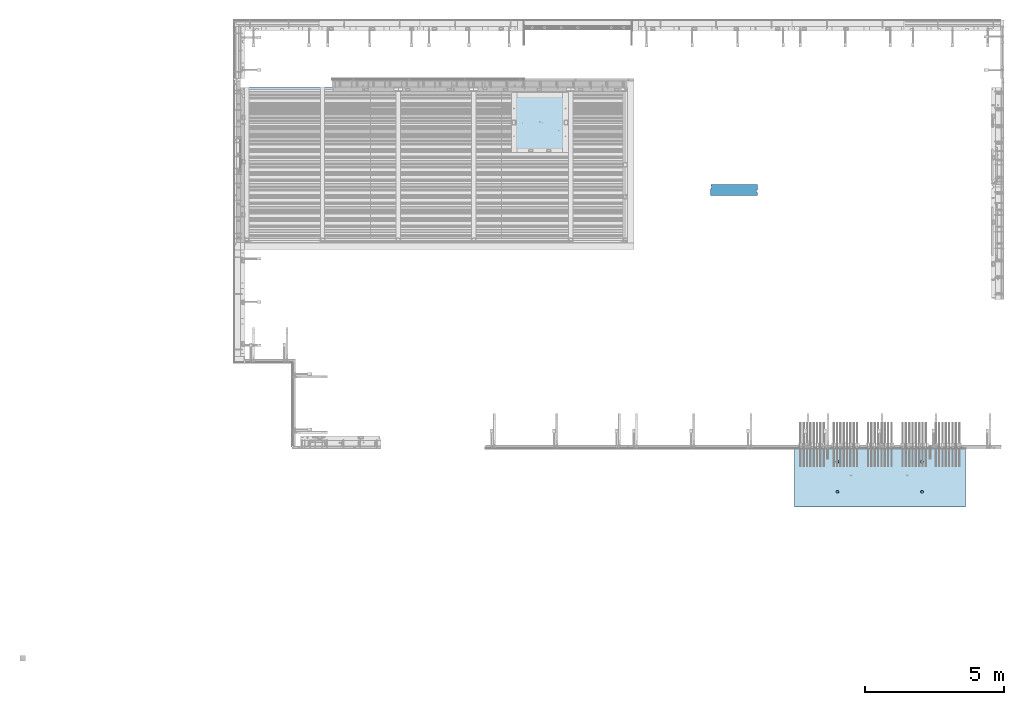
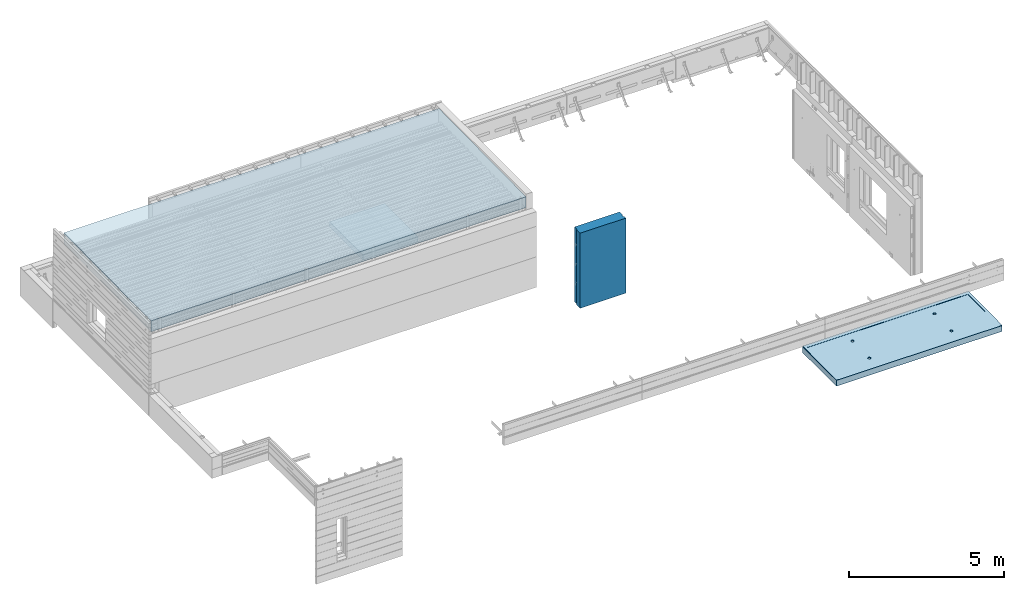
# One storey, part 69 of 153: 3 slabs, 2 plates, 4 elements without a shape of their own.
"""IFC2X3 building model written with IfcOpenShell, lengths in millimetres."""

from ifc_helpers import new_model, si_unit, frame, origin_with_axes, place, context, subcontext, project, spatial, faceted_brep, material, type_object, element, aggregate, save


model = new_model("IFC2X3")

# Units and contexts
model_context = context("Model", 3, precision=1e-05, world=origin_with_axes())
body_context = subcontext(model_context, "Body", "Model", "MODEL_VIEW")
ifc_project = project(units=[si_unit("LENGTHUNIT", "METRE", prefix="MILLI"), si_unit("AREAUNIT", "SQUARE_METRE"), si_unit("VOLUMEUNIT", "CUBIC_METRE"), si_unit("MASSUNIT", "GRAM", prefix="KILO"), si_unit("TIMEUNIT", "SECOND"), si_unit("PLANEANGLEUNIT", "RADIAN"), si_unit("SOLIDANGLEUNIT", "STERADIAN"), si_unit("THERMODYNAMICTEMPERATUREUNIT", "DEGREE_CELSIUS"), si_unit("LUMINOUSINTENSITYUNIT", "LUMEN")], contexts=[model_context])

# Site, building, storey
site_placement = place(None, origin_with_axes())
site = spatial("IfcSite", under=ifc_project, at=site_placement, CompositionType="ELEMENT")
building_placement = place(site_placement, origin_with_axes())
building = spatial("IfcBuilding", under=site, at=building_placement, CompositionType="ELEMENT")
storey_placement = place(building_placement, origin_with_axes())
storey = spatial("IfcBuildingStorey", under=building, at=storey_placement, Name="8", CompositionType="ELEMENT", Elevation=0.0)

# Assembly, slab
assembly_1_placement = place(storey_placement, origin_with_axes())
assembly_1 = element("IfcElementAssembly", 1, at=assembly_1_placement, inside=storey, AssemblyPlace="NOTDEFINED", PredefinedType="REINFORCEMENT_UNIT")
ifc_material_1 = material(Name="CONCRETE/C35/45")
slab_type_1 = type_object("IfcSlabType", PredefinedType="NOTDEFINED")
slab_1_placement = place(assembly_1_placement, frame((27819.9998568017, 7630.00344419876, 102715.0), z_axis=(-1.11800000013248e-06, -0.999999999999375, 0.0), x_axis=(0.999999999999375, -1.11799999997436e-06, 0.0)))
slab_1 = element("IfcSlab", 2, at=slab_1_placement, type_object=slab_type_1, material=ifc_material_1, PredefinedType="FLOOR", context=body_context, shape_type="Brep", body=[
    faceted_brep([(1589.81325592552, 0.909604111424414, 566.199296128498), (1588.0938311348, -15.0000000000146, 565.640623273063), (1580.9111665252, -15.0000000000146, 579.737435254802), (1582.36061370195, 0.766201307793381, 580.790517794936), (1569.72389207501, -15.0000000000146, 590.924734719762), (1570.76938061005, 0.652459661185276, 592.363722854278), (1555.62709615375, -15.0000000000146, 598.107430849813), (1556.17417970693, 0.579462587236776, 599.791174489762), (1540.00067136433, -15.0000000000146, 600.582431302958), (1540.00067334043, 0.554314810113283, 602.349967076835), (1524.37424104085, -15.0000000000146, 598.107465790505), (1523.82716125849, 0.579462416979368, 599.791210635328), (1510.27742905911, -15.0000000000146, 590.924801180907), (1509.2319437633, 0.652459337215987, 592.363791623349), (1499.09012959415, -15.0000000000146, 579.737526730721), (1497.64068481311, 0.766200861689867, 580.790612482018), (1491.9074334641, -15.0000000000146, 565.640730809456), (1490.18800997929, 0.909603586653247, 566.199407491095), (1489.43243301096, -15.0000000000146, 550.014306020037), (1487.60644765718, 1.06867111324391, 550.014308061489), (1491.90739852341, -15.0000000000146, 534.387875696556), (1490.15357958405, 1.22784849844174, 533.818027547306), (1499.090063133, -15.0000000000146, 520.291063714818), (1497.58496496165, 1.37153884480358, 519.197548455435), (1510.27733758319, -15.0000000000146, 509.103764249858), (1509.17619797228, 1.48563591431594, 507.58817916073), (1524.37413350445, -15.0000000000146, 501.921068119807), (1523.79265561132, 1.5589205318538, 500.131469988689), (1540.00055829388, -15.0000000000146, 499.446067666661), (1540.00055618693, 1.58417814118729, 497.561501968798), (1555.62698861736, -15.0000000000146, 501.921033179116), (1556.20846251496, 1.55892070285336, 500.131433729337), (1569.72380059909, -15.0000000000146, 509.103697788713), (1570.82493684288, 1.48563623946393, 507.588110207549), (1580.91110006406, -15.0000000000146, 520.290972238898), (1582.41619583143, 1.3715392920858, 519.197453584243), (1588.09379619411, -15.0000000000146, 534.387768160163), (1589.84761391607, 1.22784902394051, 533.817916070923), (1590.56879664725, -15.0000000000146, 550.014192949582), (1592.39478206378, 1.06867166540178, 550.014190908131), (100.000169136605, 4.99999899105751, 149.999887195343), (6060.00016913566, 4.99999303130608, 150.003242675352), (6060.00016914429, 13.626982540809, 150.003242675352), (100.000169145234, 13.6270007889543, 149.999887195343), (6059.99902340923, -15.0, 2184.99381483995), (6059.99902341922, -5.00001173831697, 2184.99381483995), (-0.000976555282250047, -15.0, 2185.00366210937), (99.9990234313627, -15.0, 2185.00349961318), (99.9990234413635, -4.99999981843575, 2185.00349961318), (-0.000976555282250047, -4.99999961843423, 2185.00366210937), (0.0, -15.0, 0.0), (0.0, 15.0, 0.0), (6159.99999999999, -15.0, 1.20053300634027e-10), (6159.99999999877, 14.9999889917381, 0.00275350808988151), (6159.9990234375, -15.0, 2184.99365234375), (6159.9990234375, -5.00001193831849, 2184.99365234375), (1589.77710511953, -9.43578378019447, 1618.84121999299), (1589.17575487276, -15.0000000000146, 1619.03661127579), (1591.70637331362, -15.0000000000146, 1635.01419167845), (1592.32060830134, -9.59473210806027, 1635.01419099173), (1582.35637965208, -9.29230025924335, 1604.24179400386), (1581.83164984091, -15.0000000000146, 1604.62303342371), (1570.78179862371, -9.17836747907859, 1592.64915460789), (1570.39295038797, -15.0000000000146, 1593.18435954767), (1556.18635505503, -9.10518846024934, 1585.20320708963), (1555.97935611451, -15.0000000000146, 1585.8402867446), (1540.00176930131, -9.07996736333007, 1582.63697304818), (1540.00177005342, -15.0000000000146, 1583.30970402962), (1523.81718929172, -9.10518863100151, 1585.20324329681), (1524.02418965076, -15.0000000000146, 1585.84032247048), (1509.22176238791, -9.17836780374637, 1592.64922346186), (1509.61061179868, -15.0000000000146, 1593.18442750233), (1497.64720730009, -9.29230070589983, 1604.24188873855), (1498.17193792265, -15.0000000000146, 1604.62312695526), (1490.22651449262, -9.43578430493653, 1618.84133130897), (1490.82786511957, -15.0000000000146, 1619.03672122873), (1487.68304747952, -9.59473265943234, 1635.01430797653), (1488.29728240459, -15.0000000000146, 1635.01430728981), (1490.26089534804, -9.75357131339842, 1651.17611964729), (1490.82790084545, -15.0000000000146, 1650.99188769248), (1497.70284697964, -9.89676770487858, 1665.7463302375), (1498.1720058773, -15.0000000000146, 1665.40546554456), (1509.27742796969, -10.0103455735516, 1677.30285743263), (1509.61070533024, -15.0000000000146, 1676.84413942059), (1523.85164529082, -10.0832374629535, 1684.71958958146), (1524.0242996037, -15.0000000000146, 1684.18821222366), (1540.00188628625, -10.1083488864388, 1687.27466438337), (1540.00188566478, -15.0000000000146, 1686.71879493864), (1556.15212157446, -10.083237292929, 1684.7195534879), (1555.97946606745, -15.0000000000146, 1684.18817649779), (1570.72632232738, -10.010345250048, 1677.30278876251), (1570.39304391953, -15.0000000000146, 1676.84407146594), (1582.30087749635, -9.8967672594008, 1665.74623568666), (1581.83171779556, -15.0000000000146, 1665.405372013), (1589.74279656461, -9.75357078936941, 1651.17600844493), (1589.17579059863, -15.0000000000146, 1650.99177773954), (4639.77710685512, -9.4357677033986, 1618.83780952844), (4639.17575487085, -15.0000000000146, 1619.03320137579), (4641.70637331171, -15.0000000000146, 1635.01078177845), (4642.32061012571, -9.59471603682323, 1635.01078109173), (4632.35638112863, -9.29228417745617, 1604.23838302969), (4631.831649839, -15.0000000000146, 1604.6196235237), (4620.78179969623, -9.17835139330418, 1592.64574322906), (4620.39295038606, -15.0000000000146, 1593.18094964767), (4606.18635561807, -9.10517237192835, 1585.19979545089), (4605.97935611261, -15.0000000000146, 1585.8368768446), (4590.0017692994, -9.07995127410686, 1582.63356131986), (4590.00177005151, -15.0000000000146, 1583.30629412962), (4573.81718872486, -9.10517254266597, 1585.19983165807), (4574.02418964885, -15.0000000000146, 1585.83691257048), (4559.22176131157, -9.17835171795741, 1592.64581208303), (4559.61061179677, -15.0000000000146, 1593.18101760233), (4547.64720581972, -9.2922846240981, 1604.23847776439), (4548.17193792074, -15.0000000000146, 1604.61971705526), (4540.22651275322, -9.43576822814066, 1618.83792084443), (4540.82786511767, -15.0000000000146, 1619.03331132873), (4537.68304565134, -9.5947165881953, 1635.01089807653), (4538.29728240268, -15.0000000000146, 1635.01089738981), (4540.26089360985, -9.75355524769111, 1651.17271031145), (4540.82790084355, -15.0000000000146, 1650.98847779248), (4547.70284550121, -9.89675164416258, 1665.74292141026), (4548.1720058754, -15.0000000000146, 1665.40205564456), (4559.27742689529, -10.0103295168083, 1677.29944900879), (4559.61070532833, -15.0000000000146, 1676.84072952059), (4573.85164472516, -10.0832214087568, 1684.71618141651), (4574.02429960179, -15.0000000000146, 1684.18480232366), (4590.00188628434, -10.1083328331297, 1687.27125630761), (4590.00188566288, -15.0000000000146, 1686.71538503864), (4606.15212213631, -10.0832212387468, 1684.71614532295), (4605.97946606554, -15.0000000000146, 1684.18476659779), (4620.72632339797, -10.0103291933046, 1677.29938033867), (4620.39304391763, -15.0000000000146, 1676.84066156594), (4632.30087897097, -9.89675119869935, 1665.74282685941), (4631.83171779366, -15.0000000000146, 1665.401962113), (4639.742798299, -9.75355472367664, 1651.17259910908), (4639.17579059672, -15.0000000000146, 1650.98836783954), (4560.27742905721, -15.0000000000146, 590.921391280907), (4559.2319426889, 0.652475393959321, 592.360383199507), (4573.82716069284, 0.579478471161565, 599.787802470379), (4574.37424103894, -15.0000000000146, 598.104055890504), (4549.09012959224, -15.0000000000146, 579.734116830721), (4547.64068333468, 0.766216922391322, 580.787203654775), (4541.9074334622, -15.0000000000146, 565.637320909456), (4540.18800824109, 0.909619652346009, 566.195998155254), (4539.43243300905, -15.0000000000146, 550.010896120038), (4537.60644582899, 1.06868718448095, 550.010898161491), (4541.90739852151, -15.0000000000146, 534.384465796556), (4540.15357784466, 1.22786457523762, 533.814617082763), (4549.0900631311, -15.0000000000146, 520.287653814817), (4547.58496348128, 1.37155492659076, 519.194137481273), (4560.27733758129, -15.0000000000146, 509.100354349858), (4559.17619689594, 1.48565200009034, 507.584767781906), (4574.37413350255, -15.0000000000146, 501.917658219807), (4573.79265504446, 1.55893662018934, 500.128058349949), (4590.00055829197, -15.0000000000146, 499.442657766662), (4590.00055618502, 1.58419423039595, 497.558090240479), (4605.62698861545, -15.0000000000146, 501.917623279115), (4606.208463078, 1.55893679117435, 500.128022090596), (4619.72380059719, -15.0000000000146, 509.100287888714), (4620.8249379154, 1.48565232523833, 507.584698828722), (4630.91110006215, -15.0000000000146, 520.287562338897), (4632.41619730799, 1.37155537388753, 519.194042610077), (4638.0937961922, -15.0000000000146, 534.384358260164), (4639.84761565166, 1.22786510073638, 533.814505606375), (4632.36061517657, 0.766217368509388, 580.787108967689), (4620.76938168064, 0.65247571792861, 592.360314430433), (4606.17418026878, 0.579478641418973, 599.787766324812), (4590.00067333853, 0.554330863422365, 602.346559001076), (4642.39478388815, 1.06868773663882, 550.010781008129), (4639.81325765991, 0.909620177117176, 566.195886792653), (4590.00067136242, -15.0000000000146, 600.579021402958), (4605.62709615185, -15.0000000000146, 598.104020949812), (4619.72389207311, -15.0000000000146, 590.921324819762), (4630.9111665233, -15.0000000000146, 579.734025354802), (4638.09383113289, -15.0000000000146, 565.637213373064), (4640.56879664535, -15.0000000000146, 550.010783049583)], [[[0, 1, 2, 3]], [[3, 2, 4, 5]], [[5, 4, 6, 7]], [[7, 6, 8, 9]], [[10, 11, 9, 8]], [[12, 13, 11, 10]], [[14, 15, 13, 12]], [[16, 17, 15, 14]], [[18, 19, 17, 16]], [[20, 21, 19, 18]], [[22, 23, 21, 20]], [[24, 25, 23, 22]], [[26, 27, 25, 24]], [[27, 26, 28, 29]], [[29, 28, 30, 31]], [[31, 30, 32, 33]], [[33, 32, 34, 35]], [[35, 34, 36, 37]], [[37, 36, 38, 39]], [[39, 38, 1, 0]], [[40, 41, 42, 43]], [[41, 44, 45, 42]], [[46, 47, 48, 49]], [[50, 46, 49, 51]], [[52, 50, 51, 53]], [[54, 52, 53, 55]], [[44, 54, 55, 45]], [[53, 51, 49, 48, 43, 42, 45, 55]], [[47, 40, 43, 48]], [[56, 57, 58, 59]], [[60, 61, 57, 56]], [[62, 63, 61, 60]], [[64, 65, 63, 62]], [[66, 67, 65, 64]], [[68, 69, 67, 66]], [[70, 71, 69, 68]], [[71, 70, 72, 73]], [[73, 72, 74, 75]], [[75, 74, 76, 77]], [[77, 76, 78, 79]], [[79, 78, 80, 81]], [[81, 80, 82, 83]], [[83, 82, 84, 85]], [[85, 84, 86, 87]], [[87, 86, 88, 89]], [[90, 91, 89, 88]], [[92, 93, 91, 90]], [[94, 95, 93, 92]], [[59, 58, 95, 94]], [[96, 97, 98, 99]], [[100, 101, 97, 96]], [[102, 103, 101, 100]], [[104, 105, 103, 102]], [[106, 107, 105, 104]], [[108, 109, 107, 106]], [[110, 111, 109, 108]], [[111, 110, 112, 113]], [[113, 112, 114, 115]], [[115, 114, 116, 117]], [[117, 116, 118, 119]], [[119, 118, 120, 121]], [[121, 120, 122, 123]], [[123, 122, 124, 125]], [[125, 124, 126, 127]], [[127, 126, 128, 129]], [[130, 131, 129, 128]], [[132, 133, 131, 130]], [[134, 135, 133, 132]], [[99, 98, 135, 134]], [[136, 137, 138, 139]], [[140, 141, 137, 136]], [[142, 143, 141, 140]], [[144, 145, 143, 142]], [[146, 147, 145, 144]], [[148, 149, 147, 146]], [[150, 151, 149, 148]], [[152, 153, 151, 150]], [[153, 152, 154, 155]], [[155, 154, 156, 157]], [[157, 156, 158, 159]], [[159, 158, 160, 161]], [[161, 160, 162, 163]], [[44, 41, 40, 47], [3, 5, 7, 9, 11, 13, 15, 17, 19, 21, 23, 25, 27, 29, 31, 33, 35, 37, 39, 0], [164, 165, 166, 167, 138, 137, 141, 143, 145, 147, 149, 151, 153, 155, 157, 159, 161, 163, 168, 169], [132, 130, 128, 126, 124, 122, 120, 118, 116, 114, 112, 110, 108, 106, 104, 102, 100, 96, 99, 134], [92, 90, 88, 86, 84, 82, 80, 78, 76, 74, 72, 70, 68, 66, 64, 62, 60, 56, 59, 94]], [[139, 138, 167, 170]], [[166, 171, 170, 167]], [[165, 172, 171, 166]], [[164, 173, 172, 165]], [[169, 174, 173, 164]], [[168, 175, 174, 169]], [[163, 162, 175, 168]], [[46, 50, 52, 54, 44, 47], [34, 32, 30, 28, 26, 24, 22, 20, 18, 16, 14, 12, 10, 8, 6, 4, 2, 1, 38, 36], [160, 158, 156, 154, 152, 150, 148, 146, 144, 142, 140, 136, 139, 170, 171, 172, 173, 174, 175, 162], [101, 103, 105, 107, 109, 111, 113, 115, 117, 119, 121, 123, 125, 127, 129, 131, 133, 135, 98, 97], [61, 63, 65, 67, 69, 71, 73, 75, 77, 79, 81, 83, 85, 87, 89, 91, 93, 95, 58, 57]]]),
])

# Assembly, plate
assembly_2_placement = place(storey_placement, origin_with_axes())
assembly_2 = element("IfcElementAssembly", 3, at=assembly_2_placement, inside=storey, Name="Steel Assembly", AssemblyPlace="NOTDEFINED", PredefinedType="NOTDEFINED")
ifc_material_2 = material()
plate_type_1 = type_object("IfcPlateType", PredefinedType="NOTDEFINED")
plate_1_placement = place(assembly_2_placement, frame((21787.0, 20572.0405139231, 106106.758710679), z_axis=(0.0, -0.999921884110963, -0.0124990270013851), x_axis=(-1.0, 3.00000001838171e-08, 0.0)))
plate_1 = element("IfcPlate", 4, at=plate_1_placement, type_object=plate_type_1, material=ifc_material_2, context=body_context, shape_type="Brep", body=[
    faceted_brep([(0.0, -215.000000000015, 0.0), (-0.0013580322265625, -215.000000000015, 5600.0), (-0.0013580322265625, 215.0, 5600.0), (0.0, 215.0, 0.0), (13937.0, -215.000000000015, 5600.0), (13937.0, 215.0, 5600.0), (13937.0, -215.000000000015, -1.38243194669485e-10), (13937.0, 215.0, -1.38243194669485e-10)], [[[0, 1, 2, 3]], [[1, 4, 5, 2]], [[4, 6, 7, 5]], [[6, 0, 3, 7]], [[5, 7, 3, 2]], [[6, 4, 1, 0]]]),
])
aggregate(assembly_2, [plate_1])

# Assembly, slab
assembly_3_placement = place(storey_placement, origin_with_axes())
assembly_3 = element("IfcElementAssembly", 5, at=assembly_3_placement, inside=storey, AssemblyPlace="NOTDEFINED", PredefinedType="REINFORCEMENT_UNIT")
ifc_material_3 = material(Name="CONCRETE/Concrete_Undefined")
slab_type_2 = type_object("IfcSlabType", PredefinedType="NOTDEFINED")
slab_2_placement = place(assembly_3_placement, frame((19659.999681647, 20380.0, 103350.0), z_axis=(0.0, -1.0, 0.0), x_axis=(-1.0, 3.00000001838171e-08, 0.0)))
slab_2 = element("IfcSlab", 6, at=slab_2_placement, type_object=slab_type_2, material=ifc_material_3, PredefinedType="FLOOR", context=body_context, shape_type="Brep", body=[
    faceted_brep([(0.0, -100.0, 0.0), (0.0, -100.0, 2150.00073242188), (0.0, 100.0, 2150.00073242188), (0.0, 100.0, 0.0), (2049.99975585938, -100.0, 2150.00073242188), (2049.99975585938, 100.0, 2150.00073242188), (2049.99975585938, -100.0, 0.0), (2049.99975585938, 100.0, 0.0)], [[[0, 1, 2, 3]], [[1, 4, 5, 2]], [[4, 6, 7, 5]], [[6, 0, 3, 7]], [[5, 7, 3, 2]], [[6, 4, 1, 0]]]),
])
aggregate(assembly_3, [slab_2])

# Assembly, plate
assembly_4_placement = place(storey_placement, origin_with_axes())
assembly_4 = element("IfcElementAssembly", 7, at=assembly_4_placement, inside=storey, Name="Steel Assembly", AssemblyPlace="NOTDEFINED", PredefinedType="NOTDEFINED")
ifc_material_4 = material()
plate_type_2 = type_object("IfcPlateType", PredefinedType="NOTDEFINED")
plate_2_placement = place(assembly_4_placement, frame((24780.0, 16680.0, 101255.600000381), z_axis=(0.0, 1.0, 0.0), x_axis=(1.0, 0.0, 0.0)))
plate_2 = element("IfcPlate", 8, at=plate_2_placement, type_object=plate_type_2, material=ifc_material_4, context=body_context, shape_type="Brep", body=[
    faceted_brep([(1699.99914550781, -1475.0, 110.0), (1699.99914550781, 1475.0, 110.0), (1669.99914550781, 1475.0, 110.0), (1669.99914550781, -1475.00000000001, 110.0), (1669.99914550781, 1475.0, 200.0), (1669.99914550781, -1475.00000000001, 200.0), (1699.99914550781, -1475.0, 200.0), (1699.99914550781, 1475.0, 200.0), (1699.99914550781, -1475.0, 3.63797880709171e-12), (0.0, -1475.0, 0.0), (0.0, 1475.0, 0.0), (1699.99914550781, 1475.0, 3.63797880709171e-12), (0.0, -1475.0, 230.0), (0.0, 1475.0, 230.0), (30.0, -1475.0, 243.0), (30.0, 1475.0, 243.0), (30.0, -1475.0, 400.0), (30.0, 1475.0, 400.0), (1699.99914550781, -1475.0, 400.0), (1699.99914550781, 1475.0, 400.0)], [[[0, 1, 2, 3]], [[3, 2, 4, 5]], [[6, 5, 4, 7]], [[8, 9, 10, 11]], [[10, 9, 12, 13]], [[14, 15, 13, 12]], [[16, 17, 15, 14]], [[18, 19, 17, 16]], [[19, 18, 6, 7]], [[2, 1, 11, 10, 13, 15, 17, 19, 7, 4]], [[8, 11, 1, 0]], [[18, 16, 14, 12, 9, 8, 0, 3, 5, 6]]]),
])
aggregate(assembly_4, [plate_2])

# Slab
slab_type_3 = type_object("IfcSlabType", PredefinedType="NOTDEFINED")
slab_3_placement = place(assembly_1_placement, frame((33979.9998568133, 7629.99655735226, 102585.0), z_axis=(-1.11800000013248e-06, -0.999999999999375, 0.0), x_axis=(-0.999999999999093, 1.34699999998405e-06, 0.0)))
slab_3 = element("IfcSlab", 9, at=slab_3_placement, type_object=slab_type_3, material=ifc_material_1, PredefinedType="FLOOR", context=body_context, shape_type="Brep", body=[
    faceted_brep([(64.9583792620033, 114.980015566543, 2119.00354297346), (59.9583792907433, 104.980015635199, 2119.00353623188), (54.958376556533, 114.980014717788, 2119.00362372717), (64.9417520754141, 114.989717250108, 60.0035430634471), (59.9417521041541, 104.989717318778, 60.0035363218722), (54.9417493699439, 114.989716401367, 60.0036238171633), (1585.449075041, -100.0, 1587.45803107696), (1599.38747999686, -100.0, 1594.56002275611), (1610.44905473413, -100.0, 1605.62162222708), (1617.55101524698, -100.0, 1619.56004306296), (1619.99817215818, -100.0, 1635.01089551764), (1617.55098069888, -100.0, 1650.46174250043), (1610.44898901974, -100.0, 1664.40014745629), (1599.38738954876, -100.0, 1675.46172219355), (1585.44896871288, -100.0, 1682.56368270641), (1569.99811625821, -100.0, 1685.01083961761), (1554.5472692754, -100.0, 1682.56364815832), (1540.60886431955, -100.0, 1675.46165647916), (1529.54728958229, -100.0, 1664.40005700819), (1522.44532906943, -100.0, 1650.46163617231), (1519.99817215824, -100.0, 1635.01078371764), (1522.44536361753, -100.0, 1619.55993673484), (1529.54735529668, -100.0, 1605.62153177898), (1540.60895476765, -100.0, 1594.55995704172), (1554.54737560352, -100.0, 1587.45799652886), (1569.99822805821, -100.0, 1585.01083961767), (1520.82424514455, -115.0, 1619.03320140929), (1518.29362670369, -115.0, 1635.01078181195), (1528.1683501764, -115.0, 1604.61962355721), (1539.60704962934, -115.0, 1593.18094968118), (1554.0206439028, -115.0, 1585.8368768781), (1569.99822996389, -115.0, 1583.30629416312), (1585.97581036655, -115.0, 1585.83691260398), (1600.38938821863, -115.0, 1593.18101763583), (1611.82806209466, -115.0, 1604.61971708877), (1619.17213489774, -115.0, 1619.03331136223), (1621.70271761272, -115.0, 1635.01089742332), (1619.17209917186, -115.0, 1650.98847782598), (1611.82799414001, -115.0, 1665.40205567806), (1600.38929468707, -115.0, 1676.8407295541), (1585.97570041361, -115.0, 1684.18480235717), (1569.99811435253, -115.0, 1686.71538507215), (1554.02053394986, -115.0, 1684.18476663129), (1539.60695609778, -115.0, 1676.84066159944), (1528.16828222174, -115.0, 1665.40196214651), (1520.82420941868, -115.0, 1650.98836787304), (1585.45028807101, -110.0, 502.458031077636), (1599.38869302686, -110.0, 509.560022756788), (1610.45026776412, -110.0, 520.621622227759), (1617.55222827698, -110.0, 534.560043063637), (1619.99938518817, -110.0, 550.010895518315), (1617.55219372888, -110.0, 565.461742501111), (1610.45020204973, -110.0, 579.40014745697), (1599.38860257876, -110.0, 590.461722194232), (1585.45018174289, -110.0, 597.563682707092), (1569.99932928821, -110.0, 600.010839618284), (1554.54848230541, -110.0, 597.563648158993), (1540.61007734955, -110.0, 590.461656479841), (1529.54850261228, -110.0, 579.40005700887), (1522.44654209943, -110.0, 565.461636172992), (1519.99938518824, -110.0, 550.010783718315), (1522.44657664753, -110.0, 534.559936735518), (1529.54856832667, -110.0, 520.62153177966), (1540.61016779765, -110.0, 509.559957042397), (1554.54858863353, -110.0, 502.457996529537), (1569.99944108821, -110.0, 500.010839618346), (1521.9062038232, -115.0, 534.384358293668), (1519.43120337006, -115.0, 550.010783083088), (1529.08889995325, -115.0, 520.287562372401), (1540.27619941821, -115.0, 509.100287922216), (1554.37301139995, -115.0, 501.917623312619), (1569.99944172343, -115.0, 499.442657800165), (1585.62586651286, -115.0, 501.917658253311), (1599.72266243412, -115.0, 509.100354383362), (1610.90993688431, -115.0, 520.287653848321), (1618.0926014939, -115.0, 534.384465830061), (1620.56756700635, -115.0, 550.010896153542), (1618.09256655321, -115.0, 565.637320942961), (1610.90987042316, -115.0, 579.734116864227), (1599.7225709582, -115.0, 590.921391314413), (1585.62575897646, -115.0, 598.10405592401), (1569.99932865298, -115.0, 600.579021436465), (1554.37290386356, -115.0, 598.104020983318), (1540.2761079423, -115.0, 590.921324853267), (1529.08883349211, -115.0, 579.734025388308), (1521.90616888251, -115.0, 565.637213406568), (4635.4490750391, -100.0, 1587.46144097696), (4649.38747999496, -100.0, 1594.56343265611), (4660.44905473222, -100.0, 1605.62503212708), (4667.55101524507, -100.0, 1619.56345296296), (4669.99817215627, -100.0, 1635.01430541764), (4667.55098069697, -100.0, 1650.46515240043), (4660.44898901783, -100.0, 1664.40355735629), (4649.38738954686, -100.0, 1675.46513209355), (4635.44896871098, -100.0, 1682.56709260641), (4619.9981162563, -100.0, 1685.01424951761), (4604.5472692735, -100.0, 1682.56705805831), (4590.60886431765, -100.0, 1675.46506637916), (4579.54728958038, -100.0, 1664.40346690819), (4572.44532906752, -100.0, 1650.46504607232), (4569.99817215633, -100.0, 1635.01419361764), (4572.44536361562, -100.0, 1619.56334663484), (4579.54735529477, -100.0, 1605.62494167898), (4590.60895476575, -100.0, 1594.56336694172), (4604.54737560162, -100.0, 1587.46140642886), (4619.9982280563, -100.0, 1585.01424951767), (4570.82424514264, -115.0, 1619.03661130929), (4568.29362670179, -115.0, 1635.01419171195), (4578.16835017449, -115.0, 1604.62303345721), (4589.60704962743, -115.0, 1593.18435958118), (4604.02064390089, -115.0, 1585.84028677811), (4619.99822996198, -115.0, 1583.30970406312), (4635.97581036465, -115.0, 1585.84032250398), (4650.38938821672, -115.0, 1593.18442753583), (4661.82806209276, -115.0, 1604.62312698877), (4669.17213489583, -115.0, 1619.03672126223), (4671.70271761081, -115.0, 1635.01430732332), (4669.17209916995, -115.0, 1650.99188772598), (4661.8279941381, -115.0, 1665.40546557806), (4650.38929468517, -115.0, 1676.8441394541), (4635.97570041171, -115.0, 1684.18821225717), (4619.99811435062, -115.0, 1686.71879497215), (4604.02053394795, -115.0, 1684.18817653129), (4589.60695609587, -115.0, 1676.84407149944), (4578.16828221984, -115.0, 1665.40537204651), (4570.82420941677, -115.0, 1650.99177777304), (4635.4502880691, -110.0, 502.461440977637), (4649.38869302495, -110.0, 509.563432656789), (4660.45026776222, -110.0, 520.625032127759), (4667.55222827508, -110.0, 534.563452963636), (4669.99938518627, -110.0, 550.014305418315), (4667.55219372698, -110.0, 565.465152401111), (4660.45020204783, -110.0, 579.40355735697), (4649.38860257686, -110.0, 590.465132094232), (4635.45018174098, -110.0, 597.567092607092), (4619.9993292863, -110.0, 600.014249518284), (4604.5484823035, -110.0, 597.567058058992), (4590.61007734765, -110.0, 590.46506637984), (4579.54850261038, -110.0, 579.40346690887), (4572.44654209752, -110.0, 565.465046072993), (4569.99938518633, -110.0, 550.014193618314), (4572.44657664562, -110.0, 534.563346635518), (4579.54856832477, -110.0, 520.624941679659), (4590.61016779574, -110.0, 509.563366942397), (4604.54858863162, -110.0, 502.461406429537), (4619.9994410863, -110.0, 500.014249518345), (4571.90620382129, -115.0, 534.387768193668), (4569.43120336815, -115.0, 550.014192983087), (4579.08889995135, -115.0, 520.290972272401), (4590.27619941631, -115.0, 509.103697822216), (4604.37301139805, -115.0, 501.921033212619), (4619.99944172153, -115.0, 499.446067700164), (4635.62586651095, -115.0, 501.921068153311), (4649.72266243221, -115.0, 509.103764283362), (4660.9099368824, -115.0, 520.29106374832), (4668.09260149199, -115.0, 534.387875730061), (4670.56756700445, -115.0, 550.014306053542), (4668.0925665513, -115.0, 565.640730842961), (4660.90987042126, -115.0, 579.737526764226), (4649.72257095629, -115.0, 590.924801214413), (4635.62575897455, -115.0, 598.10746582401), (4619.99932865107, -115.0, 600.582431336465), (4604.37290386165, -115.0, 598.107430883318), (4590.27610794039, -115.0, 590.924734753267), (4579.0888334902, -115.0, 579.737435288307), (4571.9061688806, -115.0, 565.640623306568), (6160.0, -115.0, -1.28238752949983e-10), (6160.0009765625, -115.0, 2185.00366210938), (0.000734332948923111, -115.0, 2184.99365234375), (7.27595761418343e-12, -115.0, 0.0), (7.27595761418343e-12, 115.0, 0.0), (6160.0, 115.0, -1.28238752949983e-10), (6160.0009765625, 115.0, 2185.00366210938), (0.000734332948923111, 115.0, 2184.99365234375), (60.0005626484926, 114.961257889707, 2130.04411478533), (60.0005693900748, 104.961257958363, 2125.04411481407), (60.0004818947782, 114.961257040966, 2120.04411207986), (6100.00056238451, 114.989717418895, 2129.99533955167), (6100.00056912608, 104.989717487566, 2124.99533958042), (6100.00048163079, 114.989716570155, 2119.9953368462)], [[[0, 1, 2]], [[3, 4, 1, 0]], [[5, 4, 3]], [[2, 1, 4, 5]], [[6, 7, 8, 9, 10, 11, 12, 13, 14, 15, 16, 17, 18, 19, 20, 21, 22, 23, 24, 25]], [[26, 21, 20, 27]], [[28, 22, 21, 26]], [[29, 23, 22, 28]], [[30, 24, 23, 29]], [[31, 25, 24, 30]], [[32, 6, 25, 31]], [[33, 7, 6, 32]], [[34, 8, 7, 33]], [[35, 9, 8, 34]], [[36, 10, 9, 35]], [[37, 11, 10, 36]], [[38, 12, 11, 37]], [[39, 13, 12, 38]], [[40, 14, 13, 39]], [[41, 15, 14, 40]], [[42, 16, 15, 41]], [[43, 17, 16, 42]], [[44, 18, 17, 43]], [[45, 19, 18, 44]], [[27, 20, 19, 45]], [[46, 47, 48, 49, 50, 51, 52, 53, 54, 55, 56, 57, 58, 59, 60, 61, 62, 63, 64, 65]], [[66, 61, 60, 67]], [[68, 62, 61, 66]], [[69, 63, 62, 68]], [[70, 64, 63, 69]], [[71, 65, 64, 70]], [[72, 46, 65, 71]], [[73, 47, 46, 72]], [[74, 48, 47, 73]], [[75, 49, 48, 74]], [[76, 50, 49, 75]], [[77, 51, 50, 76]], [[78, 52, 51, 77]], [[79, 53, 52, 78]], [[80, 54, 53, 79]], [[81, 55, 54, 80]], [[82, 56, 55, 81]], [[83, 57, 56, 82]], [[84, 58, 57, 83]], [[85, 59, 58, 84]], [[67, 60, 59, 85]], [[86, 87, 88, 89, 90, 91, 92, 93, 94, 95, 96, 97, 98, 99, 100, 101, 102, 103, 104, 105]], [[106, 101, 100, 107]], [[108, 102, 101, 106]], [[109, 103, 102, 108]], [[110, 104, 103, 109]], [[111, 105, 104, 110]], [[112, 86, 105, 111]], [[113, 87, 86, 112]], [[114, 88, 87, 113]], [[115, 89, 88, 114]], [[116, 90, 89, 115]], [[117, 91, 90, 116]], [[118, 92, 91, 117]], [[119, 93, 92, 118]], [[120, 94, 93, 119]], [[121, 95, 94, 120]], [[122, 96, 95, 121]], [[123, 97, 96, 122]], [[124, 98, 97, 123]], [[125, 99, 98, 124]], [[107, 100, 99, 125]], [[126, 127, 128, 129, 130, 131, 132, 133, 134, 135, 136, 137, 138, 139, 140, 141, 142, 143, 144, 145]], [[146, 141, 140, 147]], [[148, 142, 141, 146]], [[149, 143, 142, 148]], [[150, 144, 143, 149]], [[151, 145, 144, 150]], [[152, 126, 145, 151]], [[153, 127, 126, 152]], [[154, 128, 127, 153]], [[155, 129, 128, 154]], [[156, 130, 129, 155]], [[157, 131, 130, 156]], [[158, 132, 131, 157]], [[159, 133, 132, 158]], [[160, 134, 133, 159]], [[161, 135, 134, 160]], [[162, 136, 135, 161]], [[163, 137, 136, 162]], [[164, 138, 137, 163]], [[165, 139, 138, 164]], [[147, 140, 139, 165]], [[166, 167, 168, 169], [164, 163, 162, 161, 160, 159, 158, 157, 156, 155, 154, 153, 152, 151, 150, 149, 148, 146, 147, 165], [124, 123, 122, 121, 120, 119, 118, 117, 116, 115, 114, 113, 112, 111, 110, 109, 108, 106, 107, 125], [84, 83, 82, 81, 80, 79, 78, 77, 76, 75, 74, 73, 72, 71, 70, 69, 68, 66, 67, 85], [44, 43, 42, 41, 40, 39, 38, 37, 36, 35, 34, 33, 32, 31, 30, 29, 28, 26, 27, 45]], [[166, 169, 170, 171]], [[167, 166, 171, 172]], [[168, 167, 172, 173]], [[169, 168, 173, 170]], [[174, 175, 176]], [[177, 178, 175, 174]], [[179, 178, 177]], [[176, 175, 178, 179]], [[172, 171, 170, 173], [0, 2, 5, 3], [177, 174, 176, 179]]]),
])

aggregate(assembly_1, [slab_1, slab_3])

save(model, "model.ifc")
